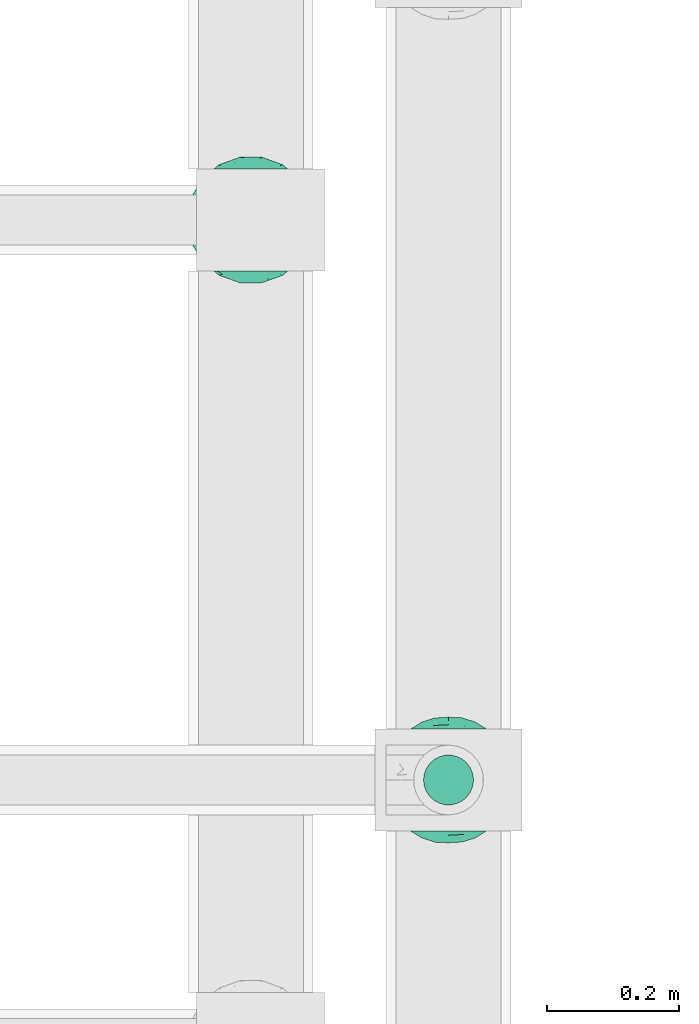
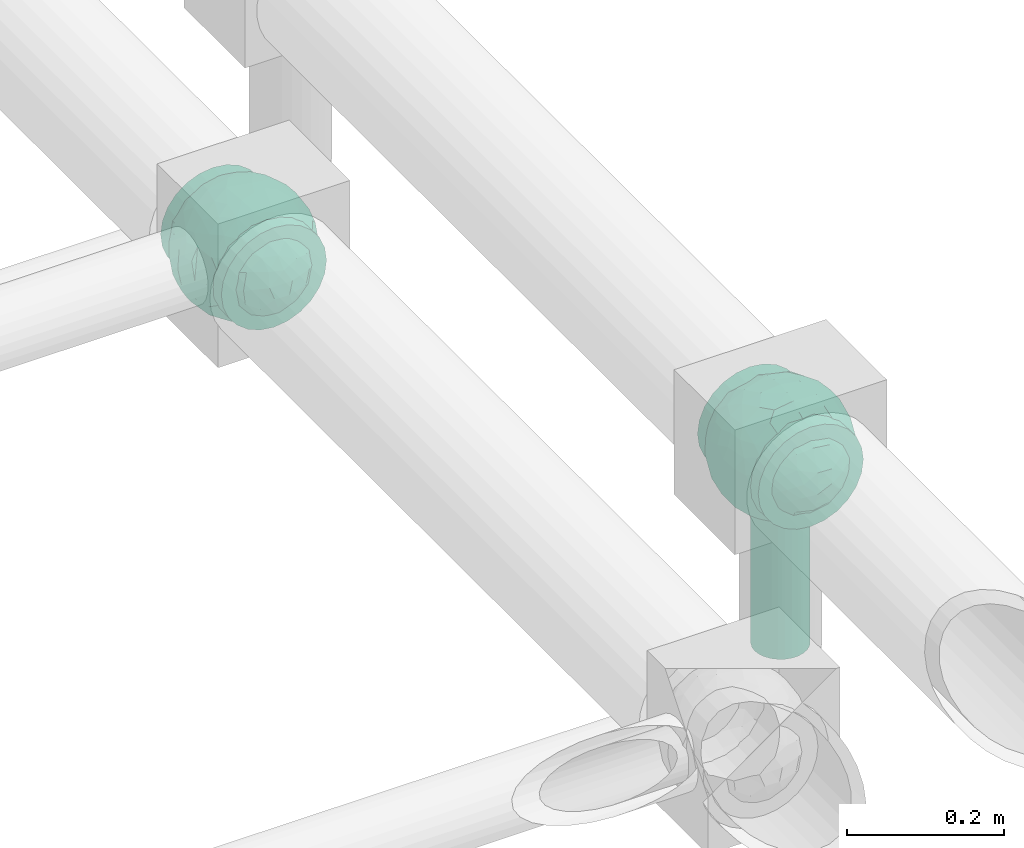
# One storey, part 619 of 827: 2 flow fittings, 1 flow segment.
"""IFC2X3 building model written with IfcOpenShell, lengths in millimetres."""

from ifc_helpers import new_model, entity, si_unit, converted_unit, derived_unit, direction, frame, origin, origin_2d_with_axis, place, context, subcontext, project, spatial, circle, extrude, faceted_brep, source, transform, mapped, material, material_list, type_object, type_shapes, element, save


model = new_model("IFC2X3")

# Units and contexts
model_context = context("Model", 3, precision=0.01, world=origin(), true_north=direction((6.12303176911189e-17, 1.0)))
body_context = subcontext(model_context, "Body", "Model", "MODEL_VIEW")
ifc_project = project(units=[si_unit("LENGTHUNIT", "METRE", prefix="MILLI"), si_unit("AREAUNIT", "SQUARE_METRE"), si_unit("VOLUMEUNIT", "CUBIC_METRE"), converted_unit("PLANEANGLEUNIT", "DEGREE", entity("IfcRatioMeasure", 0.0174532925199433), si_unit("PLANEANGLEUNIT", "RADIAN"), dimensions=[0, 0, 0, 0, 0, 0, 0]), si_unit("MASSUNIT", "GRAM", prefix="KILO"), derived_unit("MASSDENSITYUNIT", [(si_unit("MASSUNIT", "GRAM", prefix="KILO"), 1), (si_unit("LENGTHUNIT", "METRE"), -3)]), derived_unit("MOMENTOFINERTIAUNIT", [(si_unit("LENGTHUNIT", "METRE"), 4)]), si_unit("TIMEUNIT", "SECOND"), si_unit("FREQUENCYUNIT", "HERTZ"), si_unit("THERMODYNAMICTEMPERATUREUNIT", "DEGREE_CELSIUS"), derived_unit("THERMALTRANSMITTANCEUNIT", [(si_unit("MASSUNIT", "GRAM", prefix="KILO"), 1), (si_unit("THERMODYNAMICTEMPERATUREUNIT", "KELVIN"), -1), (si_unit("TIMEUNIT", "SECOND"), -3)]), derived_unit("VOLUMETRICFLOWRATEUNIT", [(si_unit("LENGTHUNIT", "METRE"), 3), (si_unit("TIMEUNIT", "SECOND"), -1)]), derived_unit("MASSFLOWRATEUNIT", [(si_unit("MASSUNIT", "GRAM", prefix="KILO"), 1), (si_unit("TIMEUNIT", "SECOND"), -1)]), derived_unit("ROTATIONALFREQUENCYUNIT", [(si_unit("TIMEUNIT", "SECOND"), -1)]), si_unit("ELECTRICCURRENTUNIT", "AMPERE"), si_unit("ELECTRICVOLTAGEUNIT", "VOLT"), si_unit("POWERUNIT", "WATT"), si_unit("FORCEUNIT", "NEWTON", prefix="KILO"), si_unit("ILLUMINANCEUNIT", "LUX"), si_unit("LUMINOUSFLUXUNIT", "LUMEN"), si_unit("LUMINOUSINTENSITYUNIT", "CANDELA"), derived_unit("USERDEFINED", [(si_unit("MASSUNIT", "GRAM", prefix="KILO"), -1), (si_unit("LENGTHUNIT", "METRE"), -2), (si_unit("TIMEUNIT", "SECOND"), 3), (si_unit("LUMINOUSFLUXUNIT", "LUMEN"), 1)]), derived_unit("LINEARVELOCITYUNIT", [(si_unit("LENGTHUNIT", "METRE"), 1), (si_unit("TIMEUNIT", "SECOND"), -1)]), si_unit("PRESSUREUNIT", "PASCAL"), derived_unit("USERDEFINED", [(si_unit("LENGTHUNIT", "METRE"), -2), (si_unit("MASSUNIT", "GRAM", prefix="KILO"), 1), (si_unit("TIMEUNIT", "SECOND"), -2)]), derived_unit("LINEARFORCEUNIT", [(si_unit("MASSUNIT", "GRAM", prefix="KILO"), 1), (si_unit("LENGTHUNIT", "METRE"), 1), (si_unit("TIMEUNIT", "SECOND"), -2), (si_unit("LENGTHUNIT", "METRE"), -1)]), derived_unit("PLANARFORCEUNIT", [(si_unit("MASSUNIT", "GRAM", prefix="KILO"), 1), (si_unit("LENGTHUNIT", "METRE"), 1), (si_unit("TIMEUNIT", "SECOND"), -2), (si_unit("LENGTHUNIT", "METRE"), -2)])], contexts=[model_context])

# Site, building, storey
site_placement = place(None, origin())
site = spatial("IfcSite", under=ifc_project, at=site_placement, CompositionType="ELEMENT")
building_placement = place(site_placement, origin())
building = spatial("IfcBuilding", under=site, at=building_placement, CompositionType="ELEMENT")
storey_placement = place(building_placement, frame((0.0, 0.0, 28200.0)))
storey = spatial("IfcBuildingStorey", under=building, at=storey_placement, Name="08", CompositionType="ELEMENT", Elevation=28200.0)

# Flow segment
pipe_segment_type = type_object("IfcPipeSegmentType", PredefinedType="NOTDEFINED")
flow_segment_placement = place(storey_placement, frame((38008.7, 10440.61, 2695.0)))
element("IfcFlowSegment", 1, at=flow_segment_placement, inside=storey, type_object=pipe_segment_type, context=body_context, shape_type="SweptSolid", body=[
    extrude(circle(Radius=38.0, at=origin_2d_with_axis()), frame((39.6, 39.6, 0.0)), (0.0, 0.0, 1.0), 222.500000000001),
])

# Flow fittings
ifc_material_1 = material()
ifc_material_2 = material(Name="ADSK_")
ifc_material_list = material_list([ifc_material_1, ifc_material_2])
pipe_fitting_type = type_object("IfcPipeFittingType", Name="ADSK_1", PredefinedType="NOTDEFINED", material=ifc_material_list)
shared_shape = source(origin(), body_context, "Body", "Brep", [
    faceted_brep([(-77.5, 38.75, -67.12), (-77.5, 20.06, -74.86), (-77.5, 0.0, -77.5), (-77.5, -20.06, -74.86), (-77.5, -38.75, -67.12), (-77.5, -54.8, -54.8), (-77.5, -67.12, -38.75), (-77.5, -74.86, -20.06), (-77.5, -76.18, -10.03), (-77.5, -77.5, 0.0), (-77.5, -76.18, 10.03), (-77.5, -74.86, 20.06), (-77.5, -67.12, 38.75), (-77.5, -54.8, 54.8), (-77.5, -38.75, 67.12), (-77.5, -20.06, 74.86), (-77.5, 0.0, 77.5), (-77.5, 20.06, 74.86), (-77.5, 38.75, 67.12), (-77.5, 54.8, 54.8), (-77.5, 67.12, 38.75), (-77.5, 74.86, 20.06), (-77.5, 77.5, 0.0), (-77.5, 74.86, -20.06), (-77.5, 67.12, -38.75), (-77.5, 54.8, -54.8), (77.5, 0.0, -77.5), (77.5, 20.06, -74.86), (77.5, 38.75, -67.12), (77.5, 54.8, -54.8), (77.5, 67.12, -38.75), (77.5, 74.86, -20.06), (77.5, 77.5, 0.0), (77.5, 74.86, 20.06), (77.5, 67.12, 38.75), (77.5, 54.8, 54.8), (77.5, 38.75, 67.12), (77.5, 20.06, 74.86), (77.5, 0.0, 77.5), (77.5, -20.06, 74.86), (77.5, -38.75, 67.12), (77.5, -54.8, 54.8), (77.5, -67.12, 38.75), (77.5, -74.86, 20.06), (77.5, -76.18, 10.03), (77.5, -77.5, 0.0), (77.5, -76.18, -10.03), (77.5, -74.86, -20.06), (77.5, -67.12, -38.75), (77.5, -54.8, -54.8), (77.5, -38.75, -67.12), (77.5, -20.06, -74.86), (32.85, -76.55, 12.09), (35.0, -77.5, 0.0), (-35.0, -77.5, 0.0), (26.77, -74.15, 22.55), (6.15, -69.42, 34.46), (17.58, -71.35, 30.26), (11.87, -70.38, 32.36), (-32.85, -76.55, 12.09), (-33.92, -77.03, 6.04), (-26.78, -74.15, 22.54), (-17.59, -71.35, 30.26), (-11.87, -70.38, 32.36), (-6.16, -69.42, 34.45), (0.0, -69.42, 34.45), (33.92, -77.03, 6.04), (6.15, -69.42, -34.46), (-32.85, -76.55, -12.09), (-33.92, -77.03, -6.04), (17.58, -71.35, -30.26), (11.87, -70.38, -32.36), (32.85, -76.55, -12.09), (26.77, -74.15, -22.55), (33.92, -77.03, -6.04), (-6.16, -69.42, -34.45), (-11.87, -70.38, -32.36), (-17.59, -71.35, -30.26), (0.0, -69.42, -34.45), (-26.78, -74.15, -22.54), (0.0, -82.5, -35.0), (9.06, -82.5, -33.81), (17.5, -82.5, -30.31), (24.75, -82.5, -24.75), (30.31, -82.5, -17.5), (33.81, -82.5, -9.06), (35.0, -82.5, 0.0), (33.81, -82.5, 9.06), (30.31, -82.5, 17.5), (24.75, -82.5, 24.75), (17.5, -82.5, 30.31), (9.06, -82.5, 33.81), (0.0, -82.5, 35.0), (-9.06, -82.5, 33.81), (-17.5, -82.5, 30.31), (-24.75, -82.5, 24.75), (-30.31, -82.5, 17.5), (-33.81, -82.5, 9.06), (-35.0, -82.5, 0.0), (-33.81, -82.5, -9.06), (-30.31, -82.5, -17.5), (-24.75, -82.5, -24.75), (-17.5, -82.5, -30.31), (-9.06, -82.5, -33.81)], [[[0, 1, 2, 3, 4, 5, 6, 7, 8, 9, 10, 11, 12, 13, 14, 15, 16, 17, 18, 19, 20, 21, 22, 23, 24, 25]], [[26, 27, 28, 29, 30, 31, 32, 33, 34, 35, 36, 37, 38, 39, 40, 41, 42, 43, 44, 45, 46, 47, 48, 49, 50, 51]], [[44, 43, 52]], [[53, 45, 44]], [[9, 54, 10]], [[43, 55, 52]], [[42, 41, 56]], [[55, 43, 57]], [[42, 56, 58, 57]], [[41, 13, 56]], [[57, 43, 42]], [[59, 11, 10]], [[10, 54, 60, 59]], [[59, 61, 11]], [[12, 62, 63, 64]], [[12, 11, 62]], [[12, 64, 13]], [[62, 11, 61]], [[13, 64, 65, 56]], [[44, 52, 66, 53]], [[41, 40, 14, 13]], [[16, 15, 39, 38]], [[15, 14, 40, 39]], [[17, 16, 38, 37]], [[34, 33, 21, 20]], [[19, 18, 36, 35]], [[20, 19, 35, 34]], [[37, 36, 18, 17]], [[22, 21, 33, 32]], [[24, 23, 31, 30]], [[23, 22, 32, 31]], [[25, 24, 30, 29]], [[26, 51, 3, 2]], [[1, 0, 28, 27]], [[2, 1, 27, 26]], [[29, 28, 0, 25]], [[4, 3, 51, 50]], [[50, 49, 5, 4]], [[49, 48, 67]], [[8, 68, 69, 54]], [[48, 70, 71, 67]], [[48, 47, 70]], [[49, 67, 5]], [[45, 53, 46]], [[8, 54, 9]], [[72, 73, 47]], [[46, 53, 74, 72]], [[47, 73, 70]], [[6, 75, 76, 77]], [[72, 47, 46]], [[6, 5, 75]], [[77, 7, 6]], [[5, 67, 78, 75]], [[79, 68, 7]], [[68, 8, 7]], [[79, 7, 77]], [[80, 81, 82, 83, 84, 85, 86, 87, 88, 89, 90, 91, 92, 93, 94, 95, 96, 97, 98, 99, 100, 101, 102, 103]], [[98, 97, 60]], [[61, 96, 95]], [[97, 96, 59]], [[95, 94, 62]], [[86, 66, 87]], [[98, 60, 54]], [[59, 96, 61]], [[93, 64, 63]], [[63, 62, 94]], [[62, 61, 95]], [[92, 56, 65, 64]], [[93, 63, 94]], [[58, 56, 91]], [[56, 92, 91]], [[92, 64, 93]], [[55, 89, 88]], [[90, 89, 57]], [[52, 88, 87]], [[90, 58, 91]], [[89, 55, 57]], [[58, 90, 57]], [[87, 66, 52]], [[52, 55, 88]], [[97, 59, 60]], [[66, 86, 53]], [[86, 85, 74]], [[73, 84, 83]], [[85, 84, 72]], [[83, 82, 70]], [[98, 69, 99]], [[86, 74, 53]], [[72, 84, 73]], [[81, 67, 71]], [[71, 70, 82]], [[70, 73, 83]], [[80, 75, 78, 67]], [[81, 71, 82]], [[76, 75, 103]], [[75, 80, 103]], [[80, 67, 81]], [[79, 101, 100]], [[101, 77, 102]], [[100, 99, 68]], [[102, 76, 103]], [[101, 79, 77]], [[76, 102, 77]], [[99, 69, 68]], [[68, 79, 100]], [[85, 72, 74]], [[69, 98, 54]]]),
    faceted_brep([(74.09, -36.62, -50.54), (86.5, -25.35, -35.5), (82.61, -45.18, -22.81), (-16.75, -33.7, -89.27), (0.0, -42.78, -86.92), (-23.87, -49.97, -79.49), (73.94, -14.61, -60.86), (53.84, -28.63, -75.28), (-16.57, 93.95, 0.0), (-18.09, 86.11, -40.53), (-32.84, 86.73, -28.0), (-44.04, -10.15, -85.69), (-19.2, 4.88, -94.83), (-22.92, -15.62, -92.82), (89.65, 32.63, 0.0), (82.61, 44.34, -24.37), (83.9, 48.44, 0.0), (47.7, -82.62, 0.0), (60.26, -69.94, -29.38), (62.27, -74.21, 0.0), (95.4, 0.0, 0.0), (95.4, -16.82, 0.0), (94.13, -8.44, -21.26), (93.14, 13.95, -22.71), (95.4, 16.82, 0.0), (76.54, 8.21, -58.81), (74.09, 36.62, -50.54), (84.96, 22.7, -40.64), (28.25, -36.42, -85.21), (19.67, -61.78, -71.98), (-67.45, 51.53, -46.69), (-45.73, 54.97, -65.36), (-59.68, 42.12, -63.64), (47.7, 82.62, 0.0), (62.27, 74.21, 0.0), (59.48, 63.11, -43.18), (-48.12, -74.69, -38.62), (-33.13, -91.03, 0.0), (-47.7, -82.62, 0.0), (72.35, 57.3, -29.46), (60.01, 43.15, -62.62), (62.52, -52.48, -52.18), (45.73, -54.97, -65.36), (-62.27, -74.21, 0.0), (-73.08, -61.32, 0.0), (-72.41, -59.62, -24.21), (7.26, -81.07, -52.53), (35.35, -68.17, -59.06), (27.87, -86.63, -33.22), (-74.09, -36.62, -50.54), (-84.35, -21.79, -42.37), (-76.59, -6.33, -58.98), (61.55, 0.0, -74.81), (-61.55, 0.0, -74.81), (-79.37, 15.54, -53.33), (-95.4, -16.82, 0.0), (-92.58, -16.52, -23.25), (-89.65, -32.63, 0.0), (63.81, 22.67, -69.28), (-18.69, 68.07, -66.35), (-42.94, 76.94, -40.26), (-74.09, 36.62, -50.54), (-43.64, 36.19, -78.55), (-65.1, 21.71, -68.38), (44.46, 15.06, -84.74), (-65.04, -21.76, -68.42), (-94.63, 4.93, -20.13), (-87.93, 0.0, -40.67), (-89.65, 32.63, 0.0), (-89.27, 26.35, -26.85), (27.96, 84.78, -37.61), (7.26, 81.07, -52.53), (1.19, 92.73, -28.0), (3.41, -92.84, -27.46), (-8.28, -95.41, 0.0), (-11.9, -93.14, -23.83), (73.08, 61.32, 0.0), (87.93, 0.0, -40.67), (73.08, -61.32, 0.0), (83.9, -48.44, 0.0), (-73.08, 61.32, 0.0), (-82.24, 45.34, -23.77), (-83.9, 48.44, 0.0), (-63.57, -59.47, -42.5), (-45.73, -54.97, -65.36), (-82.58, -43.28, -26.32), (29.11, 48.1, -78.89), (45.73, 54.97, -65.36), (44.58, 36.0, -78.11), (-61.2, 65.56, -36.61), (-6.93, -65.5, -71.03), (30.56, -5.14, -91.79), (9.54, -19.86, -94.34), (0.0, 12.89, -96.01), (47.81, -10.83, -83.56), (89.65, -32.63, 0.0), (44.95, 76.64, -38.61), (33.13, 91.03, 0.0), (28.53, 69.09, -61.62), (-51.45, 14.65, -80.76), (22.17, 26.71, -90.44), (33.13, -91.03, 0.0), (44.95, -76.64, -38.61), (72.35, -57.3, -29.46), (16.57, -93.95, 0.0), (-15.25, 22.47, -92.99), (2.72, 32.92, -91.07), (8.92, 50.75, -82.03), (9.42, 67.57, -68.78), (16.57, 93.95, 0.0), (-5.45, -87.35, -41.54), (8.28, -95.41, 0.0), (0.0, -96.88, 0.0), (-24.34, -90.45, -24.71), (-25.14, -82.23, -44.62), (-16.57, -93.95, 0.0), (-9.92, -78.26, -56.23), (-30.26, -67.58, -62.46), (-40.87, -32.58, -81.57), (-34.66, 17.97, -88.66), (-59.69, -42.16, -63.59), (-16.8, 39.61, -86.8), (-28.19, 53.95, -75.36), (-10.32, 55.25, -78.9), (-57.91, -73.21, -25.92), (-83.9, -48.44, 0.0), (-95.4, 0.0, 0.0), (-95.4, 16.82, 0.0), (-72.43, 58.81, -26.08), (-62.27, 74.21, 0.0), (-47.7, 82.62, 0.0), (-33.13, 91.03, 0.0), (0.0, 96.87, 0.0), (-74.09, -36.62, 50.54), (-86.5, -25.35, 35.5), (-82.61, -45.18, 22.81), (16.75, -33.7, 89.27), (0.0, -42.78, 86.92), (23.87, -49.97, 79.49), (-73.94, -14.61, 60.86), (-53.84, -28.63, 75.28), (18.09, 86.11, 40.53), (32.84, 86.73, 28.0), (44.04, -10.15, 85.69), (19.2, 4.88, 94.83), (22.92, -15.62, 92.82), (-82.61, 44.34, 24.37), (-60.26, -69.94, 29.38), (-94.13, -8.44, 21.26), (-93.14, 13.95, 22.71), (-76.54, 8.21, 58.81), (-74.09, 36.62, 50.54), (-84.96, 22.7, 40.64), (-28.25, -36.42, 85.21), (-19.67, -61.78, 71.98), (67.45, 51.53, 46.69), (45.73, 54.97, 65.36), (59.68, 42.12, 63.64), (-28.53, 69.09, 61.62), (-45.73, 54.97, 65.36), (-29.11, 48.1, 78.89), (48.12, -74.69, 38.62), (-59.48, 63.11, 43.18), (-72.35, 57.3, 29.46), (-60.01, 43.15, 62.62), (-35.35, -68.17, 59.06), (-7.26, -81.07, 52.53), (72.41, -59.62, 24.21), (-3.41, -92.84, 27.46), (74.09, -36.62, 50.54), (84.35, -21.79, 42.37), (76.59, -6.33, 58.98), (-61.55, 0.0, 74.81), (61.55, 0.0, 74.81), (79.37, 15.54, 53.33), (92.58, -16.52, 23.25), (-63.81, 22.67, 69.28), (18.69, 68.07, 66.35), (42.94, 76.94, 40.26), (74.09, 36.62, 50.54), (43.64, 36.19, 78.55), (65.1, 21.71, 68.38), (-44.46, 15.06, 84.74), (65.04, -21.76, 68.42), (94.63, 4.93, 20.13), (87.93, 0.0, 40.67), (89.27, 26.35, 26.85), (-27.96, 84.78, 37.61), (-7.26, 81.07, 52.53), (-1.19, 92.73, 28.0), (11.9, -93.14, 23.83), (-87.93, 0.0, 40.67), (82.24, 45.34, 23.77), (63.57, -59.47, 42.5), (45.73, -54.97, 65.36), (82.58, -43.28, 26.32), (-44.58, 36.0, 78.11), (61.2, 65.56, 36.61), (25.14, -82.23, 44.62), (5.45, -87.35, 41.54), (24.34, -90.45, 24.71), (6.93, -65.5, 71.03), (-30.56, -5.14, 91.79), (-9.54, -19.86, 94.34), (0.0, 12.89, 96.01), (-47.81, -10.83, 83.56), (-44.95, 76.64, 38.61), (51.45, 14.65, 80.76), (-62.52, -52.48, 52.18), (-45.73, -54.97, 65.36), (-22.17, 26.71, 90.44), (-44.95, -76.64, 38.61), (-72.35, -57.3, 29.46), (-27.87, -86.63, 33.22), (15.25, 22.47, 92.99), (-2.72, 32.92, 91.07), (-8.92, 50.75, 82.03), (-9.42, 67.57, 68.78), (9.92, -78.26, 56.23), (30.26, -67.58, 62.46), (40.87, -32.58, 81.57), (34.66, 17.97, 88.66), (59.69, -42.16, 63.59), (16.8, 39.61, 86.8), (28.19, 53.95, 75.36), (10.32, 55.25, 78.9), (57.91, -73.21, 25.92), (72.43, 58.81, 26.08)], [[[0, 1, 2]], [[3, 4, 5]], [[6, 0, 7]], [[8, 9, 10]], [[11, 12, 13]], [[14, 15, 16]], [[17, 18, 19]], [[20, 21, 22]], [[23, 24, 20]], [[25, 26, 27]], [[4, 28, 29]], [[30, 31, 32]], [[33, 34, 35]], [[36, 37, 38]], [[35, 39, 40]], [[41, 18, 42]], [[43, 44, 45]], [[46, 47, 48]], [[49, 50, 51]], [[52, 25, 6]], [[53, 51, 54]], [[55, 56, 57]], [[26, 25, 58]], [[59, 31, 60]], [[32, 61, 30]], [[62, 63, 32]], [[52, 64, 58]], [[51, 65, 49]], [[56, 66, 67]], [[66, 68, 69]], [[70, 71, 72]], [[73, 74, 75]], [[6, 7, 52]], [[20, 22, 23]], [[76, 39, 34]], [[15, 26, 39]], [[1, 77, 22]], [[78, 2, 79]], [[61, 54, 69]], [[80, 81, 82]], [[36, 83, 84]], [[85, 56, 50]], [[86, 87, 88]], [[60, 31, 89]], [[48, 73, 46]], [[4, 29, 90]], [[91, 92, 93]], [[7, 94, 52]], [[77, 23, 22]], [[95, 79, 2]], [[0, 6, 1]], [[1, 22, 95]], [[1, 95, 2]], [[27, 23, 77]], [[15, 14, 23]], [[25, 27, 77]], [[15, 76, 16]], [[40, 39, 26]], [[39, 76, 15]], [[96, 97, 33]], [[70, 98, 71]], [[39, 35, 34]], [[87, 86, 98]], [[77, 1, 6]], [[25, 52, 58]], [[62, 99, 63]], [[26, 15, 27]], [[6, 25, 77]], [[0, 41, 7]], [[42, 28, 7]], [[92, 91, 28]], [[94, 28, 91]], [[88, 87, 40]], [[52, 94, 64]], [[40, 26, 58]], [[100, 91, 93]], [[88, 40, 58]], [[22, 21, 95]], [[101, 102, 17]], [[103, 78, 19]], [[41, 0, 103]], [[18, 102, 42]], [[101, 48, 102]], [[101, 104, 48]], [[29, 28, 42]], [[28, 4, 92]], [[102, 47, 42]], [[90, 29, 46]], [[88, 58, 64]], [[40, 87, 35]], [[87, 96, 35]], [[33, 35, 96]], [[100, 64, 91]], [[88, 64, 100]], [[12, 105, 93]], [[98, 96, 87]], [[106, 100, 93]], [[86, 100, 107]], [[100, 86, 88]], [[98, 108, 71]], [[108, 86, 107]], [[109, 70, 72]], [[70, 109, 97]], [[96, 98, 70]], [[97, 96, 70]], [[78, 103, 2]], [[0, 2, 103]], [[41, 103, 18]], [[7, 41, 42]], [[19, 18, 103]], [[102, 18, 17]], [[75, 110, 73]], [[73, 104, 111, 112]], [[113, 114, 110]], [[115, 75, 74]], [[36, 114, 37]], [[90, 5, 4]], [[73, 48, 104]], [[47, 46, 29]], [[46, 116, 90]], [[5, 117, 84]], [[90, 116, 117]], [[118, 13, 3]], [[118, 5, 84]], [[11, 119, 12]], [[65, 120, 49]], [[11, 13, 118]], [[63, 53, 54]], [[121, 122, 123]], [[90, 117, 5]], [[49, 120, 83]], [[117, 36, 84]], [[36, 117, 114]], [[43, 45, 124]], [[38, 124, 36]], [[83, 124, 45]], [[85, 125, 57]], [[125, 85, 44]], [[45, 49, 83]], [[66, 55, 126, 127]], [[57, 56, 85]], [[56, 67, 50]], [[51, 50, 67]], [[85, 50, 49]], [[54, 51, 67]], [[51, 53, 65]], [[69, 54, 67]], [[54, 61, 63]], [[69, 67, 66]], [[128, 129, 89]], [[11, 65, 53]], [[120, 118, 84]], [[32, 63, 61]], [[99, 53, 63]], [[118, 120, 65]], [[83, 120, 84]], [[129, 128, 80]], [[62, 32, 31]], [[60, 130, 131]], [[130, 60, 89]], [[9, 71, 59]], [[10, 60, 131]], [[108, 59, 71]], [[71, 9, 72]], [[62, 121, 119]], [[122, 59, 123]], [[62, 119, 99]], [[62, 31, 122]], [[106, 107, 100]], [[44, 85, 45]], [[49, 45, 85]], [[55, 66, 56]], [[62, 122, 121]], [[89, 129, 130]], [[65, 11, 118]], [[11, 53, 99]], [[80, 128, 81]], [[30, 128, 89]], [[81, 61, 69]], [[61, 81, 128]], [[82, 81, 69]], [[10, 59, 60]], [[72, 8, 132]], [[8, 72, 9]], [[109, 72, 132]], [[3, 92, 4]], [[92, 13, 12]], [[23, 27, 15]], [[14, 24, 23]], [[11, 99, 119]], [[128, 30, 61]], [[31, 30, 89]], [[28, 94, 7]], [[64, 94, 91]], [[48, 47, 102]], [[29, 42, 47]], [[105, 106, 93]], [[123, 106, 121]], [[86, 108, 98]], [[108, 107, 123]], [[73, 112, 74]], [[113, 75, 115]], [[114, 116, 110]], [[115, 37, 113]], [[37, 114, 113]], [[46, 73, 110]], [[117, 116, 114]], [[110, 75, 113]], [[46, 110, 116]], [[118, 3, 5]], [[92, 3, 13]], [[105, 119, 121]], [[92, 12, 93]], [[119, 105, 12]], [[106, 105, 121]], [[43, 124, 38]], [[83, 36, 124]], [[68, 66, 127]], [[68, 82, 69]], [[31, 59, 122]], [[108, 123, 59]], [[106, 123, 107]], [[8, 10, 131]], [[59, 10, 9]], [[133, 134, 135]], [[136, 137, 138]], [[139, 133, 140]], [[109, 141, 142]], [[143, 144, 145]], [[68, 146, 82]], [[38, 147, 43]], [[148, 126, 55]], [[149, 127, 126]], [[150, 151, 152]], [[137, 153, 154]], [[155, 156, 157]], [[158, 159, 160]], [[161, 101, 17]], [[162, 163, 164]], [[154, 165, 166]], [[19, 78, 167]], [[168, 115, 74, 112]], [[169, 170, 171]], [[172, 150, 139]], [[173, 171, 174]], [[21, 175, 95]], [[151, 150, 176]], [[177, 156, 178]], [[157, 179, 155]], [[180, 181, 157]], [[172, 182, 176]], [[171, 183, 169]], [[175, 184, 185]], [[186, 24, 14, 16]], [[187, 188, 189]], [[168, 111, 190]], [[139, 140, 172]], [[126, 148, 149]], [[80, 163, 129]], [[146, 151, 163]], [[134, 191, 148]], [[44, 135, 125]], [[179, 174, 186]], [[76, 192, 16]], [[161, 193, 194]], [[195, 175, 170]], [[160, 159, 196]], [[178, 156, 197]], [[198, 199, 200]], [[137, 154, 201]], [[202, 203, 204]], [[140, 205, 172]], [[134, 133, 139]], [[125, 135, 57]], [[148, 191, 149]], [[134, 148, 57]], [[134, 57, 135]], [[152, 149, 191]], [[146, 68, 149]], [[150, 152, 191]], [[146, 80, 82]], [[164, 163, 151]], [[163, 80, 146]], [[162, 130, 129]], [[130, 206, 131]], [[163, 162, 129]], [[158, 188, 187]], [[191, 134, 139]], [[150, 172, 176]], [[180, 207, 181]], [[151, 146, 152]], [[139, 150, 191]], [[133, 208, 140]], [[209, 153, 140]], [[203, 202, 153]], [[205, 153, 202]], [[196, 159, 164]], [[172, 205, 182]], [[164, 151, 176]], [[210, 202, 204]], [[196, 164, 176]], [[148, 55, 57]], [[38, 37, 211]], [[212, 44, 43]], [[208, 133, 212]], [[147, 211, 209]], [[165, 213, 166]], [[209, 208, 147]], [[154, 153, 209]], [[153, 137, 203]], [[211, 165, 209]], [[201, 154, 166]], [[196, 176, 182]], [[164, 159, 162]], [[159, 206, 162]], [[130, 162, 206]], [[210, 182, 202]], [[196, 182, 210]], [[144, 214, 204]], [[158, 206, 159]], [[215, 210, 204]], [[160, 210, 216]], [[210, 160, 196]], [[158, 217, 188]], [[217, 160, 216]], [[8, 187, 189]], [[187, 8, 131]], [[206, 158, 187]], [[131, 206, 187]], [[44, 212, 135]], [[133, 135, 212]], [[208, 212, 147]], [[140, 208, 209]], [[43, 147, 212]], [[211, 147, 38]], [[199, 168, 190]], [[213, 115, 168]], [[213, 168, 166]], [[104, 190, 111]], [[161, 198, 101]], [[201, 138, 137]], [[37, 115, 213]], [[211, 37, 213]], [[166, 218, 201]], [[138, 219, 194]], [[201, 218, 219]], [[220, 145, 136]], [[220, 138, 194]], [[143, 221, 144]], [[183, 222, 169]], [[143, 145, 220]], [[181, 173, 174]], [[223, 224, 225]], [[201, 219, 138]], [[169, 222, 193]], [[219, 161, 194]], [[161, 219, 198]], [[19, 167, 226]], [[17, 226, 161]], [[193, 226, 167]], [[195, 79, 95]], [[79, 195, 78]], [[167, 169, 193]], [[184, 21, 20, 24]], [[95, 175, 195]], [[175, 185, 170]], [[171, 170, 185]], [[195, 170, 169]], [[174, 171, 185]], [[171, 173, 183]], [[186, 174, 185]], [[174, 179, 181]], [[186, 185, 184]], [[227, 34, 197]], [[143, 183, 173]], [[222, 220, 194]], [[157, 181, 179]], [[207, 173, 181]], [[220, 222, 183]], [[193, 222, 194]], [[34, 227, 76]], [[180, 157, 156]], [[178, 33, 97]], [[33, 178, 197]], [[141, 188, 177]], [[142, 178, 97]], [[217, 177, 188]], [[188, 141, 189]], [[180, 223, 221]], [[224, 177, 225]], [[180, 221, 207]], [[180, 156, 224]], [[215, 216, 210]], [[78, 195, 167]], [[169, 167, 195]], [[21, 184, 175]], [[186, 184, 24]], [[197, 34, 33]], [[183, 143, 220]], [[143, 173, 207]], [[76, 227, 192]], [[155, 227, 197]], [[192, 179, 186]], [[179, 192, 227]], [[16, 192, 186]], [[142, 177, 178]], [[189, 109, 132]], [[109, 189, 141]], [[8, 189, 132]], [[136, 203, 137]], [[203, 145, 144]], [[149, 152, 146]], [[68, 127, 149]], [[143, 207, 221]], [[227, 155, 179]], [[156, 155, 197]], [[153, 205, 140]], [[182, 205, 202]], [[213, 165, 211]], [[154, 209, 165]], [[214, 215, 204]], [[225, 215, 223]], [[160, 217, 158]], [[217, 216, 225]], [[168, 112, 111]], [[200, 190, 104]], [[198, 218, 199]], [[104, 101, 200]], [[101, 198, 200]], [[166, 168, 199]], [[219, 218, 198]], [[199, 190, 200]], [[166, 199, 218]], [[220, 136, 138]], [[203, 136, 145]], [[214, 221, 223]], [[203, 144, 204]], [[221, 214, 144]], [[215, 214, 223]], [[19, 226, 17]], [[193, 161, 226]], [[180, 224, 223]], [[156, 177, 224]], [[217, 225, 177]], [[215, 225, 216]], [[109, 142, 97]], [[177, 142, 141]]]),
])
type_shapes(pipe_fitting_type, [shared_shape])
for number, where, z_axis, x_axis, name in (
    (2, (38048.3, 10480.2, 3000.0), (-1.0, 0.0, 0.0), (0.0, -1.0, 0.0), "ADSK_1"),
    (3, (37748.3, 11330.2, 2899.91), (0.0, 7.18992412176744e-07, 1.0), (0.0, -1.0, 7.18992412176744e-07), "ADSK_1"),
):
    element("IfcFlowFitting", number, at=place(storey_placement, frame(where, z_axis=z_axis, x_axis=x_axis)), inside=storey, type_object=pipe_fitting_type, material=ifc_material_list, Name=name, ObjectType="ADSK_1", context=body_context, shape_type="MappedRepresentation", body=[
        mapped(shared_shape, transform((0.0, 0.0, 0.0), scale=1.0)),
    ])

save(model, "model.ifc")
